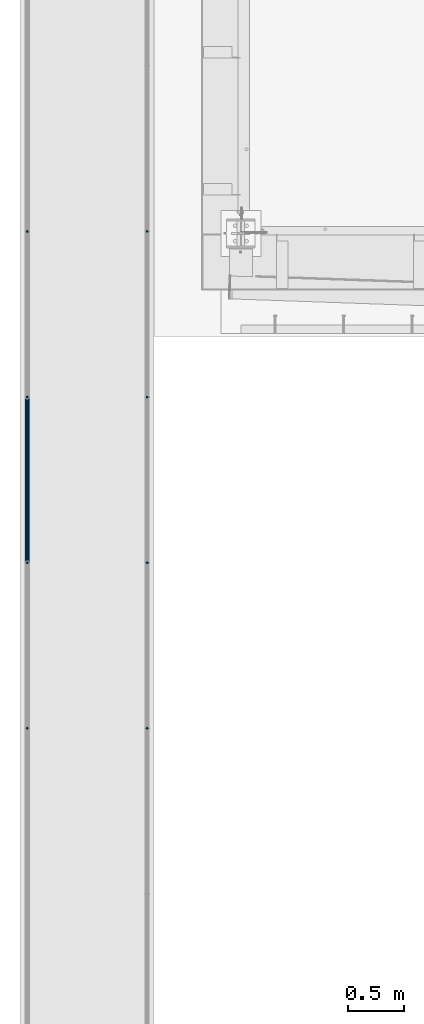
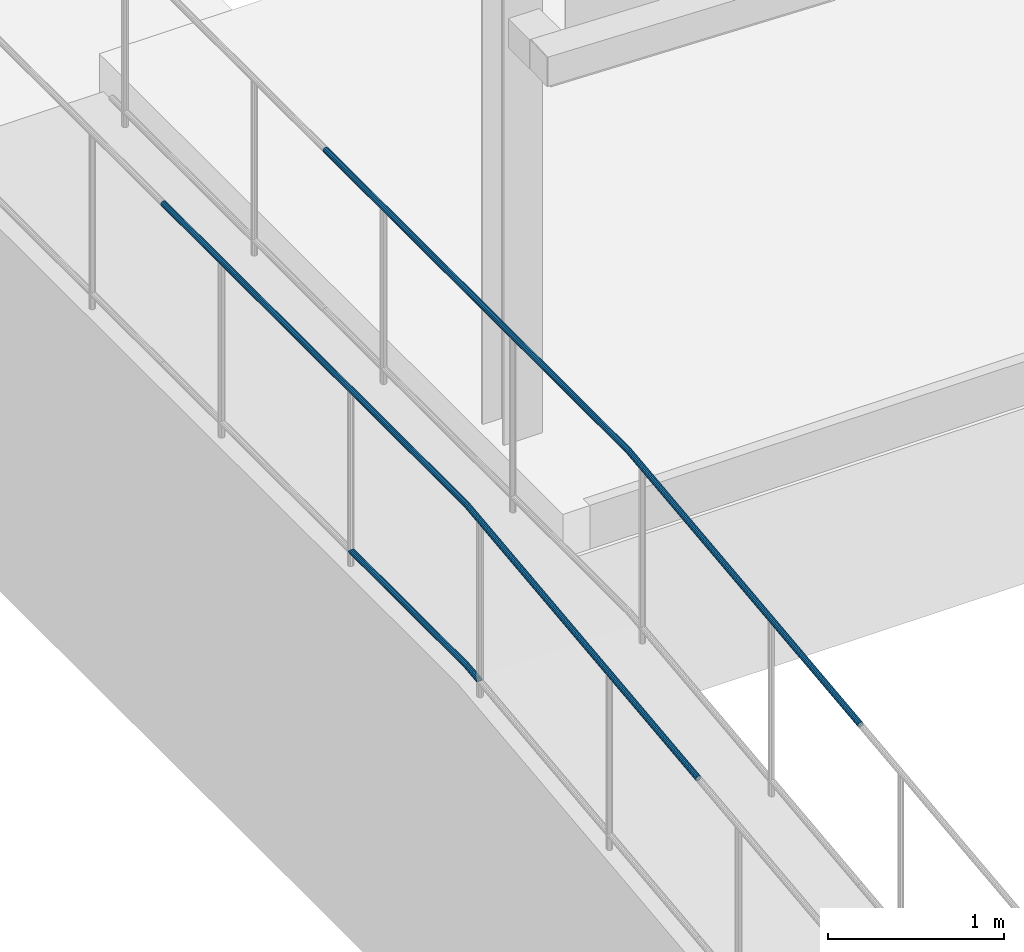
# One storey, part 1045 of 1763: 3 beams, 2 elements without a shape of their own.
"""IFC2X3 building model written with IfcOpenShell, lengths in millimetres."""

import ifcopenshell
import ifcopenshell.guid

model = None  # the IFC model being written
_history = None  # IfcOwnerHistory: only IFC2X3 demands one
_inside = {}  # id of a spatial element -> (the spatial element, [elements in it])
_under = {}  # id of a project, library or spatial element -> (it, [spatial elements below it])
_declared = {}  # id of a project -> (the project, [libraries it declares])
_typed = {}  # id of a type object -> (the type object, [elements of that type])
_made_of = {}  # id of a material, layer set ... -> (it, [elements and type objects made of it])


def new_model(schema):
    """Start an empty IFC model of exactly this schema.

    Asked for "IFC4X3", IfcOpenShell would pick the latest addendum, in which some entities
    have other attributes; the version numbers below select the first issue.
    IFC2X3 requires an IfcOwnerHistory on every rooted entity: one is made here for all.
    """
    global model, _history
    if schema == "IFC4X3":
        model = ifcopenshell.file(schema_version=(4, 3, 0, 0))
    else:
        model = ifcopenshell.file(schema=schema)
    _inside.clear()
    _under.clear()
    _declared.clear()
    _typed.clear()
    _made_of.clear()
    _history = None
    if model.schema == "IFC2X3":
        org = make("IfcOrganization", Name="unknown")
        user = make(
            "IfcPersonAndOrganization",
            ThePerson=make("IfcPerson", FamilyName="unknown"),
            TheOrganization=org,
        )
        app = make(
            "IfcApplication",
            ApplicationDeveloper=org,
            Version="unknown",
            ApplicationFullName="unknown",
            ApplicationIdentifier="unknown",
        )
        _history = make(
            "IfcOwnerHistory",
            OwningUser=user,
            OwningApplication=app,
            ChangeAction="ADDED",
            CreationDate=0,
        )
    return model


def make(cls, **values):
    """One entity of the class cls with the attributes given. An attribute that is None is left unset."""
    return model.create_entity(
        cls, **{name: value for name, value in values.items() if value is not None}
    )


def rooted(cls, **values):
    """An entity with a GlobalId (a new one), such as an element, a storey or a relation."""
    return make(cls, GlobalId=ifcopenshell.guid.new(), OwnerHistory=_history, **values)


def si_unit(unit_type, name, prefix=None):
    """IfcSIUnit, for example si_unit("LENGTHUNIT", "METRE", prefix="MILLI")."""
    return make("IfcSIUnit", UnitType=unit_type, Prefix=prefix, Name=name)


def assignment(units):
    """IfcUnitAssignment: the units of a project."""
    return None if units is None else make("IfcUnitAssignment", Units=units)


def point(xyz):
    """IfcCartesianPoint."""
    return None if xyz is None else make("IfcCartesianPoint", Coordinates=xyz)


def direction(xyz):
    """IfcDirection."""
    return None if xyz is None else make("IfcDirection", DirectionRatios=xyz)


def frame(location, z_axis=None, x_axis=None):
    """IfcAxis2Placement3D, a coordinate frame: its origin and axes. An axis left out is left unset."""
    return make(
        "IfcAxis2Placement3D",
        Location=point(location),
        Axis=direction(z_axis),
        RefDirection=direction(x_axis),
    )


def origin_with_axes():
    """The frame at (0, 0, 0) with the z axis (0, 0, 1) and the x axis (1, 0, 0) written out."""
    return frame((0.0, 0.0, 0.0), z_axis=(0.0, 0.0, 1.0), x_axis=(1.0, 0.0, 0.0))


def place(relative_to, where):
    """IfcLocalPlacement: puts the frame where relative to a parent placement (None: the world)."""
    return make(
        "IfcLocalPlacement", PlacementRelTo=relative_to, RelativePlacement=where
    )


def context(
    kind, dimensions, precision=None, world=None, true_north=None, identifier=None
):
    """IfcGeometricRepresentationContext, for example the 3D "Model" context."""
    return make(
        "IfcGeometricRepresentationContext",
        ContextIdentifier=identifier,
        ContextType=kind,
        CoordinateSpaceDimension=dimensions,
        Precision=precision,
        WorldCoordinateSystem=world,
        TrueNorth=true_north,
    )


def subcontext(parent, identifier, kind, view, scale=None):
    """IfcGeometricRepresentationSubContext, for example "Body" below "Model"."""
    return make(
        "IfcGeometricRepresentationSubContext",
        ContextIdentifier=identifier,
        ContextType=kind,
        ParentContext=parent,
        TargetScale=scale,
        TargetView=view,
    )


def project(units=None, contexts=None):
    """IfcProject with its units and contexts."""
    return rooted(
        "IfcProject",
        Name="project",
        RepresentationContexts=contexts,
        UnitsInContext=assignment(units),
    )


def spatial(cls, under=None, at=None, **own):
    """A site, building, storey or space (cls), placed at a placement, below another one or the project."""
    s = rooted(cls, ObjectPlacement=at, **own)
    if under is not None:
        _under.setdefault(under.id(), (under, []))[1].append(s)
    return s


def faces_of(points, faces, orient=None, outer=None):
    """IfcFace entities. A face is a list of loops; a loop is a list of indices into points, from 0.

    orient and outer hold one flag for each loop. By default every Orientation is true, the
    first loop of a face is its IfcFaceOuterBound and the others are IfcFaceBound.
    """
    made = []
    for i, loops in enumerate(faces):
        bounds = []
        for j, loop in enumerate(loops):
            is_outer = j == 0 if outer is None else outer[i][j]
            bounds.append(
                make(
                    "IfcFaceOuterBound" if is_outer else "IfcFaceBound",
                    Bound=make("IfcPolyLoop", Polygon=[points[k] for k in loop]),
                    Orientation=True if orient is None else orient[i][j],
                )
            )
        made.append(make("IfcFace", Bounds=bounds))
    return made


def faceted_brep(points, faces, orient=None, outer=None, voids=None):
    """IfcFacetedBrep: a solid bounded by flat faces; with voids (closed shells), ...WithVoids."""
    shared = [point(p) for p in points]
    hull = make("IfcClosedShell", CfsFaces=faces_of(shared, faces, orient, outer))
    if voids is None:
        return make("IfcFacetedBrep", Outer=hull)
    return make(
        "IfcFacetedBrepWithVoids",
        Outer=hull,
        Voids=[
            make(cls, CfsFaces=faces_of(shared, fs, o, b)) for cls, fs, o, b in voids
        ],
    )


def shape(context_of_items, identifier, shape_type, items):
    """IfcShapeRepresentation: the items that make up one representation, for example the "Body"."""
    return make(
        "IfcShapeRepresentation",
        ContextOfItems=context_of_items,
        RepresentationIdentifier=identifier,
        RepresentationType=shape_type,
        Items=items,
    )


def material(Name=None, Category=None):
    """IfcMaterial."""
    return make("IfcMaterial", Name=Name, Category=Category)


def made_of(thing, what):
    """Note that an element or type object is made of a material, layer set ...; save() writes the relation."""
    if what is not None:
        _made_of.setdefault(what.id(), (what, []))[1].append(thing)
    return thing


def type_object(cls, material=None, **own):
    """A type object (cls), such as IfcWallType, which elements share."""
    return made_of(rooted(cls, **own), material)


def element(
    cls,
    number,
    at=None,
    inside=None,
    cuts=None,
    type_object=None,
    material=None,
    context=None,
    identifier="Body",
    shape_type=None,
    held_by="IfcProductDefinitionShape",
    body=None,
    shapes=None,
    **own,
):
    """One element of the class cls, such as IfcWall. Its Tag is "e" and its number.

    at: its placement. inside: the storey or other place that contains it. cuts: it is an
    opening in that element (IfcRelVoidsElement). A single representation is given by context,
    identifier, shape_type and body (its items); several are given by shapes. held_by: the class
    of the entity that holds the representations. save() writes the other relations.
    """
    e = rooted(cls, Tag="e%d" % number, ObjectPlacement=at, **own)
    if body is not None:
        shapes = [shape(context, identifier, shape_type, body)]
    if shapes is not None:
        e.Representation = make(held_by, Representations=shapes)
    if inside is not None:
        _inside.setdefault(inside.id(), (inside, []))[1].append(e)
    if cuts is not None:
        rooted(
            "IfcRelVoidsElement", RelatingBuildingElement=cuts, RelatedOpeningElement=e
        )
    if type_object is not None:
        _typed.setdefault(type_object.id(), (type_object, []))[1].append(e)
    return made_of(e, material)


def aggregate(whole, parts):
    """IfcRelAggregates: a whole, such as a stair, and the parts it consists of."""
    return rooted("IfcRelAggregates", RelatingObject=whole, RelatedObjects=parts)


def save(model, path):
    """Write the relations noted so far, then the file.

    IfcRelAggregates (storeys below a building ...), IfcRelContainedInSpatialStructure (elements
    in a storey), IfcRelDefinesByType, IfcRelAssociatesMaterial and IfcRelDeclares: one each for
    every whole, place, type object, material and project.
    """
    for whole, parts in _under.values():
        aggregate(whole, parts)
    for where, things in _inside.values():
        rooted(
            "IfcRelContainedInSpatialStructure",
            RelatedElements=things,
            RelatingStructure=where,
        )
    for kind, things in _typed.values():
        rooted("IfcRelDefinesByType", RelatedObjects=things, RelatingType=kind)
    for what, things in _made_of.values():
        rooted("IfcRelAssociatesMaterial", RelatedObjects=things, RelatingMaterial=what)
    for by, libraries in _declared.values():
        rooted("IfcRelDeclares", RelatingContext=by, RelatedDefinitions=libraries)
    model.write(path)


model = new_model("IFC2X3")

# Units and contexts
model_context = context("Model", 3, precision=1e-05, world=origin_with_axes())
body_context = subcontext(model_context, "Body", "Model", "MODEL_VIEW")
ifc_project = project(units=[si_unit("LENGTHUNIT", "METRE", prefix="MILLI"), si_unit("AREAUNIT", "SQUARE_METRE"), si_unit("VOLUMEUNIT", "CUBIC_METRE"), si_unit("MASSUNIT", "GRAM", prefix="KILO"), si_unit("TIMEUNIT", "SECOND"), si_unit("PLANEANGLEUNIT", "RADIAN"), si_unit("SOLIDANGLEUNIT", "STERADIAN"), si_unit("THERMODYNAMICTEMPERATUREUNIT", "DEGREE_CELSIUS"), si_unit("LUMINOUSINTENSITYUNIT", "LUMEN")], contexts=[model_context])

# Site, building, storey
site_placement = place(None, origin_with_axes())
site = spatial("IfcSite", under=ifc_project, at=site_placement, CompositionType="ELEMENT")
building_placement = place(site_placement, origin_with_axes())
building = spatial("IfcBuilding", under=site, at=building_placement, Name="Undefined", CompositionType="ELEMENT")
storey_placement = place(building_placement, origin_with_axes())
storey = spatial("IfcBuildingStorey", under=building, at=storey_placement, Name="Undefined", CompositionType="ELEMENT", Elevation=0.0)

# Assembly, beams
assembly_1_placement = place(storey_placement, origin_with_axes())
assembly_1 = element("IfcElementAssembly", 1, at=assembly_1_placement, inside=storey, Name="GUARDRAIL", AssemblyPlace="NOTDEFINED", PredefinedType="RIGID_FRAME")
ifc_material = material(Name="STEEL/A513")
beam_type = type_object("IfcBeamType", PredefinedType="NOTDEFINED")
beam_1_placement = place(assembly_1_placement, frame((-97200.6527017878, 7842.04321744867, 6031.68571661139), z_axis=(0.0, 0.000110293999990972, 0.999999993917617), x_axis=(0.0, -0.999999993917617, 0.000110293999990572)))
beam_1 = element("IfcBeam", 2, at=beam_1_placement, type_object=beam_type, material=ifc_material, Name="GUARDRAIL", context=body_context, shape_type="Brep", body=[
    faceted_brep([(0.0, 19.0500000000029, 0.0), (9.52389918579229, 16.4977839420899, -9.52500000270356), (9.5259929141539, 16.4977839420899, 9.52499999728934), (9.5259929141539, -16.4977839420899, 9.52499999728934), (9.52389918579229, -16.4977839420899, -9.52500000270356), (0.0, -19.0500000000029, 0.0), (16.4995432561273, -9.52499999999418, 16.4977839373987), (16.4989903061414, -9.52499999999418, 11.4667123752624), (12.7153621018151, -13.3082123799541, 7.68349999638394), (10.6557299988963, -15.3669999999984, -3.02861735690385e-09), (12.7136731609353, -13.3082123799541, -7.68350000361079), (16.4964697622117, -9.52499999999418, -11.4667123846402), (16.4959168122259, -9.52499999999418, -16.4977839467765), (19.048257166618, 0.0, -15.367000005409), (19.0478523791344, 0.0, -19.0500000054071), (16.9896958093113, -7.68349999999919, -13.3082123847798), (16.9896958093104, 7.68349999999919, -13.3082123847798), (16.4964697622117, 9.52499999999418, -11.4667123846402), (16.4959168122259, 9.52499999999418, -16.4977839467765), (12.7136731609326, 13.3082123799541, -7.68350000361079), (10.6557299988926, 15.3669999999984, -3.02861735690385e-09), (12.7153621018115, 13.3082123799541, 7.68349999638394), (16.4989903061414, 9.52499999999418, 11.4667123752624), (16.4995432561273, 9.52499999999418, 16.4977839373987), (16.9926211407237, 7.68349999999919, 13.3082123751219), (19.0516350483749, 0.0, 15.3669999945805), (19.0520398358585, 0.0, 19.0499999945787), (16.9926211407255, -7.68349999999919, 13.3082123751219), (1319.9343412278, 7.68349999999919, 13.3082120047329), (1319.9343412262, 13.3082123799541, 7.68349962477896), (1321.9654584977, 13.3082123799541, 7.68349962420052), (1322.2876046557, 7.68349999999919, 13.3082120040635), (1323.98329424224, 13.3082123799541, 7.45160249476521), (1324.62548003482, 7.68349999999919, 13.0395347388976), (1456.21371452531, 7.68349999999919, -2.08307072021216), (1460.48971040597, 13.3082123799541, -8.23621854998237), (1456.70694273159, 9.52499999999418, -3.99337519920118), (1323.10605213563, 15.3669999999984, -0.181654905345567), (1462.54766257699, 15.3669999999984, -16.2067993071423), (1321.52539866214, 15.3669999999984, -3.75671334040817e-07), (1319.93434122402, 15.3669999999984, -3.75219315174036e-07), (1319.93434122183, 13.3082123799541, -7.68350037521668), (1321.08533882658, 13.3082123799541, -7.68350037554319), (1322.22881002902, 13.3082123799541, -7.81491230545726), (1460.48808908531, 13.3082123799541, -23.7041788217603), (1321.58662423644, 7.68349999999919, -13.4028445495896), (1456.21090631555, 7.68349999999919, -28.874363800388), (1456.70452310281, 9.52499999999418, -27.0774711894464), (1320.76319266858, 7.68349999999919, -13.3082127554053), (1319.93434122024, 7.68349999999919, -13.3082127551697), (1319.93434121965, 0.0, -15.3670003752131), (1320.64527899102, 0.0, -15.367000375415), (1321.35156792241, 0.0, -15.448169705568), (1454.15192626841, 0.0, -30.7100769108065), (1319.9343412186, 0.0, -19.0500003752131), (1319.93434121933, -9.52499999999418, -16.4977843173065), (1319.93434122131, -16.4977839420899, -9.52500037521531), (1319.93434122402, -19.0500000000029, -3.75219315174036e-07), (1320.97986994037, -16.4977839420899, -9.52500037551363), (1321.52539866214, -19.0500000000029, -3.75670424546115e-07), (1319.93434122672, -16.4977839420899, 9.52499962477941), (1319.93434122871, -9.52499999999418, 16.4977835668697), (1319.93434122943, 0.0, 19.0499996247754), (1319.93434122131, 16.4977839420899, -9.52500037521531), (1319.93434121933, 9.52499999999418, -16.4977843173065), (1319.93434122402, 19.0500000000029, -3.75219315174036e-07), (1319.93434122672, 16.4977839420899, 9.52499962477941), (1319.93434122871, 9.52499999999418, 16.4977835668697), (1320.58051519905, 9.52499999999418, -16.4977843174911), (1320.4343412186, 0.0, -19.0500003753541), (1320.58051519905, -9.52499999999418, -16.4977843174911), (1321.22246383085, -9.52499999999418, -16.5715594230041), (1322.01856192082, -16.4977839420899, -9.6443706906075), (1323.10605213563, -19.0500000000029, -0.181654905345567), (1322.07092738391, -16.4977839420899, 9.52499962417096), (1324.19354235044, -16.4977839420899, 9.28106087991546), (1322.47028212523, -9.52499999999418, 16.4977835661493), (1322.61645610568, 0.0, 19.0499996240133), (1322.47028212523, 9.52499999999418, 16.4977835661493), (1322.07092738391, 16.4977839420899, 9.52499962417096), (1321.52539866214, 19.0500000000029, -3.75670424546115e-07), (1320.97986994037, 16.4977839420899, -9.52500037551363), (1322.01856192082, 16.4977839420899, -9.6443706906075), (1321.22246383085, 9.52499999999418, -16.5715594230041), (1320.93107170602, 0.0, -19.1070864758694), (1454.15153768743, 0.0, -34.4172740007371), (1456.70399229131, -9.52499999999418, -32.1415965911274), (1463.67742795313, -16.4977839420899, -25.9243302864352), (1473.20331821774, -19.0500000000029, -17.4313969549685), (1463.67943785478, -16.4977839420899, -6.74917292472765), (1324.98964044041, -9.52499999999418, 16.2082496123112), (1456.70747354309, -9.52499999999418, 1.07075020247976), (1325.28103256525, 0.0, 18.7437766651783), (1324.98964044041, 9.52499999999418, 16.2082496123112), (1324.19354235044, 16.4977839420899, 9.28106087991546), (1323.10605213563, 19.0500000000029, -0.181654905345567), (1473.20340864678, 19.0500000000029, -17.4313969644472), (1463.67742795313, 16.4977839420899, -25.9243302864352), (1456.70399229131, 9.52499999999418, -32.1415965911274), (1456.70452310281, -9.52499999999418, -27.0774711894464), (1456.21090631555, -7.68349999999919, -28.8743638003871), (1321.58662423644, -7.68349999999919, -13.4028445495896), (1320.76319266858, -7.68349999999919, -13.3082127554053), (1319.93434122024, -7.68349999999919, -13.3082127551697), (1319.93434122183, -13.3082123799541, -7.68350037521668), (1321.08533882658, -13.3082123799541, -7.68350037554319), (1322.22881002902, -13.3082123799541, -7.81491230545726), (1460.4880890853, -13.3082123799541, -23.7041788217603), (1323.10605213563, -15.3669999999984, -0.181654905345567), (1462.54766257699, -15.3669999999984, -16.2067993071414), (1321.52539866214, -15.3669999999984, -3.75670424546115e-07), (1319.93434122402, -15.3669999999984, -3.75219315174036e-07), (1319.9343412262, -13.3082123799541, 7.68349962477896), (1321.9654584977, -13.3082123799541, 7.68349962420052), (1323.98329424224, -13.3082123799541, 7.45160249476521), (1460.48971040597, -13.3082123799541, -8.23621854998237), (1456.70694273159, -9.52499999999418, -3.99337519920118), (1324.62548003482, -7.68349999999919, 13.0395347388976), (1456.21371452531, -7.68349999999919, -2.08307072021216), (1322.2876046557, -7.68349999999919, 13.3082120040635), (1319.9343412278, -7.68349999999919, 13.3082120047329), (1319.93434122838, 0.0, 15.3669996247763), (1322.40551833326, 0.0, 15.3669996240733), (1324.86053634886, 0.0, 15.084859894876), (1454.15516890974, 0.0, 0.225843632748365), (1454.15555749073, 0.0, 3.93304072267892), (1456.70747354309, 9.52499999999418, 1.07075020247976), (1463.67943785478, 16.4977839420899, -6.74917292472765)], [[[0, 1, 2]], [[3, 4, 5]], [[6, 7, 8, 9, 10, 11, 12, 4, 3]], [[13, 14, 12, 11, 15]], [[16, 17, 18, 14, 13]], [[2, 1, 18, 17, 19, 20, 21, 22, 23]], [[23, 22, 24, 25, 26]], [[26, 25, 27, 7, 6]], [[28, 29, 30, 31]], [[31, 30, 32, 33]], [[34, 33, 32, 35, 36]], [[32, 37, 38, 35]], [[30, 39, 37, 32]], [[29, 40, 39, 30]], [[40, 41, 42, 39]], [[39, 42, 43, 37]], [[37, 43, 44, 38]], [[43, 45, 46, 47, 44]], [[42, 48, 45, 43]], [[41, 49, 48, 42]], [[49, 50, 51, 48]], [[48, 51, 52, 45]], [[45, 52, 53, 46]], [[54, 55, 12, 14]], [[55, 56, 4, 12]], [[57, 56, 58, 59]], [[56, 57, 5, 4]], [[57, 60, 3, 5]], [[60, 61, 6, 3]], [[61, 62, 26, 6]], [[63, 64, 18, 1]], [[65, 63, 1, 0]], [[66, 65, 0, 2]], [[67, 66, 2, 23]], [[62, 67, 23, 26]], [[64, 54, 14, 18]], [[54, 64, 68, 69]], [[55, 54, 69, 70]], [[56, 55, 70, 58]], [[58, 70, 71, 72]], [[59, 58, 72, 73]], [[74, 59, 73, 75]], [[60, 57, 59, 74]], [[61, 60, 74, 76]], [[62, 61, 76, 77]], [[67, 62, 77, 78]], [[66, 67, 78, 79]], [[65, 66, 79, 80]], [[63, 65, 80, 81]], [[64, 63, 81, 68]], [[68, 81, 82, 83]], [[69, 68, 83, 84]], [[70, 69, 84, 71]], [[71, 84, 85, 86]], [[72, 71, 86, 87]], [[73, 72, 87, 88]], [[88, 87, 89]], [[75, 73, 88, 89]], [[90, 75, 89, 91]], [[76, 74, 75, 90]], [[77, 76, 90, 92]], [[78, 77, 92, 93]], [[79, 78, 93, 94]], [[80, 79, 94, 95]], [[81, 80, 95, 82]], [[82, 95, 96, 97]], [[83, 82, 97, 98]], [[84, 83, 98, 85]], [[46, 53, 85, 98, 47]], [[99, 86, 85, 53, 100]], [[52, 101, 100, 53]], [[51, 102, 101, 52]], [[50, 103, 102, 51]], [[103, 104, 105, 102]], [[102, 105, 106, 101]], [[100, 101, 106, 107, 99]], [[106, 108, 109, 107]], [[105, 110, 108, 106]], [[104, 111, 110, 105]], [[111, 112, 113, 110]], [[110, 113, 114, 108]], [[108, 114, 115, 109]], [[89, 87, 86, 99, 107, 109, 115, 116, 91]], [[114, 117, 118, 116, 115]], [[113, 119, 117, 114]], [[112, 120, 119, 113]], [[120, 121, 122, 119]], [[119, 122, 123, 117]], [[117, 123, 124, 118]], [[91, 116, 118, 124, 125]], [[92, 90, 91, 125]], [[93, 92, 125, 126]], [[94, 93, 126, 127]], [[95, 94, 127, 96]], [[96, 127, 97]], [[126, 36, 35, 38, 44, 47, 98, 97, 127]], [[125, 124, 34, 36, 126]], [[123, 33, 34, 124]], [[122, 31, 33, 123]], [[121, 28, 31, 122]], [[28, 121, 25, 24]], [[21, 29, 28, 24, 22]], [[40, 29, 21, 20]], [[41, 40, 20, 19]], [[49, 41, 19, 17, 16]], [[50, 49, 16, 13]], [[103, 50, 13, 15]], [[10, 104, 103, 15, 11]], [[111, 104, 10, 9]], [[112, 111, 9, 8]], [[120, 112, 8, 7, 27]], [[121, 120, 27, 25]]]),
])
beam_2_placement = place(assembly_1_placement, frame((-97200.6527017878, 9975.70609643673, 7149.43146284773), z_axis=(1.0, 0.0, 0.0), x_axis=(0.0, -1.0, 0.0)))
beam_2 = element("IfcBeam", 3, at=beam_2_placement, type_object=beam_type, material=ifc_material, Name="GUARDRAIL", context=body_context, shape_type="Brep", body=[
    faceted_brep([(0.0, -19.0500000000029, 0.0), (0.0, -16.4977839420899, -9.52500000000146), (3453.59822932825, -16.4977839420935, -9.52499999999418), (3453.59822932825, -19.0500000000002, 0.0), (0.0, -9.52499999999418, -16.4977839420935), (3453.59822932825, -9.52499999999964, -16.4977839420899), (1.45519152283669e-11, 1.81898940354586e-12, -19.0499999999993), (3453.59822932825, 0.0, -19.0500000000029), (0.0, 9.52499999999418, -16.4977839420935), (3453.59822932825, 9.52499999999964, -16.4977839420899), (0.0, 16.4977839420899, -9.52500000000146), (3453.59822932825, 16.4977839420935, -9.52499999999418), (0.0, 19.0500000000029, 0.0), (3453.59822932825, 19.0500000000002, 0.0), (0.0, 16.4977839420899, 9.52500000000146), (3453.59822932825, 16.4977839420935, 9.52499999999418), (0.0, 9.52499999999418, 16.4977839420935), (3453.59822932825, 9.52499999999964, 16.4977839420899), (1.45519152283669e-11, 1.81898940354586e-12, 19.0499999999993), (3453.59822932825, 0.0, 19.0500000000029), (0.0, -9.52499999999418, 16.4977839420935), (3453.59822932825, -9.52499999999964, 16.4977839420899), (0.0, -16.4977839420899, 9.52500000000146), (3453.59822932825, -16.4977839420935, 9.52499999999418), (4.71409293822944e-08, -15.3669999999984, 0.0), (-1.81898940354586e-12, -13.3082123799541, 7.68349999999919), (3453.59822932825, -13.3082123799559, 7.68349999999919), (3453.59822932825, -15.3670000000002, 0.0), (-3.63797880709171e-12, -7.68349999999919, 13.3082123799531), (3453.59822932825, -7.68350000000009, 13.3082123799541), (-1.81898940354586e-12, 0.0, 15.3669999999966), (3453.59822932825, 0.0, 15.3669999999984), (-3.63797880709171e-12, 7.68349999999919, 13.3082123799531), (3453.59822932825, 7.68350000000009, 13.3082123799541), (-1.81898940354586e-12, 13.3082123799541, 7.68349999999919), (3453.59822932825, 13.3082123799559, 7.68349999999919), (4.71409293822944e-08, 15.3669999999984, 0.0), (3453.59822932825, 15.3670000000002, 0.0), (3.63797880709171e-12, 13.3082123799541, -7.68349999999737), (3453.59822932825, 13.3082123799559, -7.68349999999919), (3.63797880709171e-12, 7.68349999999919, -13.3082123799522), (3453.59822932825, 7.68350000000009, -13.3082123799541), (3.63797880709171e-12, 0.0, -15.3669999999956), (3453.59822932825, 0.0, -15.3669999999984), (3.63797880709171e-12, -7.68349999999919, -13.3082123799522), (3453.59822932825, -7.68350000000009, -13.3082123799541), (3.63797880709171e-12, -13.3082123799541, -7.68349999999737), (3453.59822932825, -13.3082123799559, -7.68349999999919), (3456.13220279116, -16.4977839420935, -9.52499999999418), (3456.2782355155, -19.0500000000002, 0.0), (3455.73323396869, -9.52499999999964, -16.4977839420899), (3455.18823242188, 0.0, -19.0500000000029), (3454.64323087506, 9.52499999999964, -16.4977839420899), (3454.24426205259, 16.4977839420935, -9.52499999999418), (3454.09822932825, 19.0500000000002, 0.0), (3454.24426205259, 16.4977839420935, 9.52499999999418), (3454.64323087506, 9.52499999999964, 16.4977839420899), (3455.18823242188, 0.0, 19.0500000000029), (3455.73323396869, -9.52499999999964, 16.4977839420899), (3456.13220279116, -16.4977839420935, 9.52499999999418), (3455.9497018531, -13.3082123799559, 7.68349999999919), (3456.06750158407, -15.3670000000002, 0.0), (3455.62786700297, -7.68350000000009, 13.3082123799541), (3455.18823242188, 0.0, 15.3669999999984), (3454.74859784078, 7.68350000000009, 13.3082123799541), (3454.42676299065, 13.3082123799559, 7.68349999999919), (3454.30896325968, 15.3670000000002, 0.0), (3454.42676299065, 13.3082123799559, -7.68349999999919), (3454.74859784078, 7.68350000000009, -13.3082123799541), (3455.18823242188, 0.0, -15.3669999999984), (3455.62786700297, -7.68350000000009, -13.3082123799541), (3455.9497018531, -13.3082123799559, -7.68349999999919), (3458.6496384423, -16.2087523640621, -9.52499999999418), (3458.94075081798, -18.7443115510987, 0.0), (3457.85430464124, -9.28147583948248, -16.4977839420899), (3456.76785846449, 0.181359872134635, -19.0500000000029), (3455.68141228775, 9.64419558375084, -16.4977839420899), (3454.88607848669, 16.5714721083314, -9.52499999999418), (3454.59496611101, 19.1070312953671, 0.0), (3454.88607848669, 16.5714721083314, 9.52499999999418), (3455.68141228775, 9.64419558375084, 16.4977839420899), (3456.76785846449, 0.181359872134635, 19.0500000000029), (3457.85430464124, -9.28147583948248, 16.4977839420899), (3458.6496384423, -16.2087523640621, 9.52499999999418), (3458.28582764659, -13.0399973317308, 7.68349999999919), (3458.52065829631, -15.0853484092731, 0.0), (3457.6442583804, -7.45199426856925, 13.3082123799541), (3456.76785846449, 0.181359872134635, 15.3669999999984), (3455.89145854859, 7.81471401283852, 13.3082123799541), (3455.2498892824, 13.402717076, 7.68349999999919), (3455.01505863268, 15.4480681535424, 0.0), (3455.2498892824, 13.402717076, -7.68349999999919), (3455.89145854859, 7.81471401283852, -13.3082123799541), (3456.76785846449, 0.181359872134635, -15.3669999999984), (3457.6442583804, -7.45199426856925, -13.3082123799541), (3458.28582764659, -13.0399973317308, -7.68349999999919), (6097.8817799778, 286.806512519663, -9.52499999999418), (6098.17289235348, 284.270953332627, 0.0), (6097.08644617674, 293.733789044243, -16.4977839420899), (6096.0, 303.196624755859, -19.0500000000029), (6094.91355382326, 312.659460467476, -16.4977839420899), (6094.1182200222, 319.586736992056, -9.52499999999418), (6093.82710764652, 322.122296179092, 0.0), (6094.1182200222, 319.586736992056, 9.52499999999418), (6094.91355382326, 312.659460467476, 16.4977839420899), (6096.0, 303.196624755859, 19.0500000000029), (6097.08644617674, 293.733789044243, 16.4977839420899), (6097.8817799778, 286.806512519663, 9.52499999999418), (6097.51796918209, 289.975267551994, 7.68349999999919), (6097.75279983181, 287.929916474452, 0.0), (6096.8763999159, 295.563270615155, 13.3082123799541), (6096.0, 303.196624755859, 15.3669999999984), (6095.1236000841, 310.829978896563, 13.3082123799541), (6094.48203081791, 316.417981959725, 7.68349999999919), (6094.24720016819, 318.463333037267, 0.0), (6094.48203081791, 316.417981959725, -7.68349999999919), (6095.1236000841, 310.829978896563, -13.3082123799541), (6096.0, 303.196624755859, -15.3669999999984), (6096.8763999159, 295.563270615155, -13.3082123799541), (6097.51796918209, 289.975267551994, -7.68349999999919)], [[[0, 1, 2, 3]], [[1, 4, 5, 2]], [[4, 6, 7, 5]], [[6, 8, 9, 7]], [[8, 10, 11, 9]], [[10, 12, 13, 11]], [[12, 14, 15, 13]], [[14, 16, 17, 15]], [[16, 18, 19, 17]], [[18, 20, 21, 19]], [[20, 22, 23, 21]], [[22, 0, 3, 23]], [[24, 25, 26, 27]], [[25, 28, 29, 26]], [[28, 30, 31, 29]], [[30, 32, 33, 31]], [[32, 34, 35, 33]], [[34, 36, 37, 35]], [[36, 38, 39, 37]], [[38, 40, 41, 39]], [[40, 42, 43, 41]], [[42, 44, 45, 43]], [[44, 46, 47, 45]], [[46, 24, 27, 47]], [[22, 20, 18, 16, 14, 12, 10, 8, 6, 4, 1, 0], [46, 44, 42, 40, 38, 36, 34, 32, 30, 28, 25, 24]], [[3, 2, 48, 49]], [[2, 5, 50, 48]], [[5, 7, 51, 50]], [[7, 9, 52, 51]], [[9, 11, 53, 52]], [[11, 13, 54, 53]], [[13, 15, 55, 54]], [[15, 17, 56, 55]], [[17, 19, 57, 56]], [[19, 21, 58, 57]], [[21, 23, 59, 58]], [[23, 3, 49, 59]], [[27, 26, 60, 61]], [[26, 29, 62, 60]], [[29, 31, 63, 62]], [[31, 33, 64, 63]], [[33, 35, 65, 64]], [[35, 37, 66, 65]], [[37, 39, 67, 66]], [[39, 41, 68, 67]], [[41, 43, 69, 68]], [[43, 45, 70, 69]], [[45, 47, 71, 70]], [[47, 27, 61, 71]], [[49, 48, 72, 73]], [[48, 50, 74, 72]], [[50, 51, 75, 74]], [[51, 52, 76, 75]], [[52, 53, 77, 76]], [[53, 54, 78, 77]], [[54, 55, 79, 78]], [[55, 56, 80, 79]], [[56, 57, 81, 80]], [[57, 58, 82, 81]], [[58, 59, 83, 82]], [[59, 49, 73, 83]], [[61, 60, 84, 85]], [[60, 62, 86, 84]], [[62, 63, 87, 86]], [[63, 64, 88, 87]], [[64, 65, 89, 88]], [[65, 66, 90, 89]], [[66, 67, 91, 90]], [[67, 68, 92, 91]], [[68, 69, 93, 92]], [[69, 70, 94, 93]], [[70, 71, 95, 94]], [[71, 61, 85, 95]], [[73, 72, 96, 97]], [[72, 74, 98, 96]], [[74, 75, 99, 98]], [[75, 76, 100, 99]], [[76, 77, 101, 100]], [[77, 78, 102, 101]], [[78, 79, 103, 102]], [[79, 80, 104, 103]], [[80, 81, 105, 104]], [[81, 82, 106, 105]], [[82, 83, 107, 106]], [[83, 73, 97, 107]], [[85, 84, 108, 109]], [[84, 86, 110, 108]], [[86, 87, 111, 110]], [[87, 88, 112, 111]], [[88, 89, 113, 112]], [[89, 90, 114, 113]], [[90, 91, 115, 114]], [[91, 92, 116, 115]], [[92, 93, 117, 116]], [[93, 94, 118, 117]], [[94, 95, 119, 118]], [[95, 85, 109, 119]], [[98, 99, 100, 101, 102, 103, 104, 105, 106, 107, 97, 96], [110, 111, 112, 113, 114, 115, 116, 117, 118, 119, 109, 108]]]),
])
aggregate(assembly_1, [beam_1, beam_2])

# Assembly, beam
assembly_2_placement = place(storey_placement, origin_with_axes())
assembly_2 = element("IfcElementAssembly", 4, at=assembly_2_placement, inside=storey, Name="GUARDRAIL", AssemblyPlace="NOTDEFINED", PredefinedType="RIGID_FRAME")
beam_3_placement = place(assembly_2_placement, frame((-96133.8527017878, 9975.70609643673, 7149.43146284773), z_axis=(1.0, 0.0, 0.0), x_axis=(0.0, -1.0, 0.0)))
beam_3 = element("IfcBeam", 5, at=beam_3_placement, type_object=beam_type, material=ifc_material, Name="GUARDRAIL", context=body_context, shape_type="Brep", body=[
    faceted_brep([(0.0, -19.0500000000029, 0.0), (0.0, -16.4977839420899, -9.52500000000146), (3453.59822932825, -16.4977839420935, -9.52499999999418), (3453.59822932825, -19.0500000000002, 0.0), (0.0, -9.52499999999418, -16.4977839420935), (3453.59822932825, -9.52499999999964, -16.4977839420899), (1.45519152283669e-11, 1.81898940354586e-12, -19.0499999999993), (3453.59822932825, 0.0, -19.0500000000029), (0.0, 9.52499999999418, -16.4977839420935), (3453.59822932825, 9.52499999999964, -16.4977839420899), (0.0, 16.4977839420899, -9.52500000000146), (3453.59822932825, 16.4977839420935, -9.52499999999418), (0.0, 19.0500000000029, 0.0), (3453.59822932825, 19.0500000000002, 0.0), (0.0, 16.4977839420899, 9.52500000000146), (3453.59822932825, 16.4977839420935, 9.52499999999418), (0.0, 9.52499999999418, 16.4977839420935), (3453.59822932825, 9.52499999999964, 16.4977839420899), (1.45519152283669e-11, 1.81898940354586e-12, 19.0499999999993), (3453.59822932825, 0.0, 19.0500000000029), (0.0, -9.52499999999418, 16.4977839420935), (3453.59822932825, -9.52499999999964, 16.4977839420899), (0.0, -16.4977839420899, 9.52500000000146), (3453.59822932825, -16.4977839420935, 9.52499999999418), (4.71409293822944e-08, -15.3669999999984, 0.0), (-1.81898940354586e-12, -13.3082123799541, 7.68349999999919), (3453.59822932825, -13.3082123799559, 7.68349999999919), (3453.59822932825, -15.3670000000002, 0.0), (-3.63797880709171e-12, -7.68349999999919, 13.3082123799531), (3453.59822932825, -7.68350000000009, 13.3082123799541), (-1.81898940354586e-12, 0.0, 15.3669999999966), (3453.59822932825, 0.0, 15.3669999999984), (-3.63797880709171e-12, 7.68349999999919, 13.3082123799531), (3453.59822932825, 7.68350000000009, 13.3082123799541), (-1.81898940354586e-12, 13.3082123799541, 7.68349999999919), (3453.59822932825, 13.3082123799559, 7.68349999999919), (4.71409293822944e-08, 15.3669999999984, 0.0), (3453.59822932825, 15.3670000000002, 0.0), (3.63797880709171e-12, 13.3082123799541, -7.68349999999737), (3453.59822932825, 13.3082123799559, -7.68349999999919), (3.63797880709171e-12, 7.68349999999919, -13.3082123799522), (3453.59822932825, 7.68350000000009, -13.3082123799541), (3.63797880709171e-12, 0.0, -15.3669999999956), (3453.59822932825, 0.0, -15.3669999999984), (3.63797880709171e-12, -7.68349999999919, -13.3082123799522), (3453.59822932825, -7.68350000000009, -13.3082123799541), (3.63797880709171e-12, -13.3082123799541, -7.68349999999737), (3453.59822932825, -13.3082123799559, -7.68349999999919), (3456.13220279116, -16.4977839420935, -9.52499999999418), (3456.2782355155, -19.0500000000002, 0.0), (3455.73323396869, -9.52499999999964, -16.4977839420899), (3455.18823242188, 0.0, -19.0500000000029), (3454.64323087506, 9.52499999999964, -16.4977839420899), (3454.24426205259, 16.4977839420935, -9.52499999999418), (3454.09822932825, 19.0500000000002, 0.0), (3454.24426205259, 16.4977839420935, 9.52499999999418), (3454.64323087506, 9.52499999999964, 16.4977839420899), (3455.18823242188, 0.0, 19.0500000000029), (3455.73323396869, -9.52499999999964, 16.4977839420899), (3456.13220279116, -16.4977839420935, 9.52499999999418), (3455.9497018531, -13.3082123799559, 7.68349999999919), (3456.06750158407, -15.3670000000002, 0.0), (3455.62786700297, -7.68350000000009, 13.3082123799541), (3455.18823242188, 0.0, 15.3669999999984), (3454.74859784078, 7.68350000000009, 13.3082123799541), (3454.42676299065, 13.3082123799559, 7.68349999999919), (3454.30896325968, 15.3670000000002, 0.0), (3454.42676299065, 13.3082123799559, -7.68349999999919), (3454.74859784078, 7.68350000000009, -13.3082123799541), (3455.18823242188, 0.0, -15.3669999999984), (3455.62786700297, -7.68350000000009, -13.3082123799541), (3455.9497018531, -13.3082123799559, -7.68349999999919), (3458.6496384423, -16.2087523640621, -9.52499999999418), (3458.94075081798, -18.7443115510987, 0.0), (3457.85430464124, -9.28147583948248, -16.4977839420899), (3456.76785846449, 0.181359872134635, -19.0500000000029), (3455.68141228775, 9.64419558375084, -16.4977839420899), (3454.88607848669, 16.5714721083314, -9.52499999999418), (3454.59496611101, 19.1070312953671, 0.0), (3454.88607848669, 16.5714721083314, 9.52499999999418), (3455.68141228775, 9.64419558375084, 16.4977839420899), (3456.76785846449, 0.181359872134635, 19.0500000000029), (3457.85430464124, -9.28147583948248, 16.4977839420899), (3458.6496384423, -16.2087523640621, 9.52499999999418), (3458.28582764659, -13.0399973317308, 7.68349999999919), (3458.52065829631, -15.0853484092731, 0.0), (3457.6442583804, -7.45199426856925, 13.3082123799541), (3456.76785846449, 0.181359872134635, 15.3669999999984), (3455.89145854859, 7.81471401283852, 13.3082123799541), (3455.2498892824, 13.402717076, 7.68349999999919), (3455.01505863268, 15.4480681535424, 0.0), (3455.2498892824, 13.402717076, -7.68349999999919), (3455.89145854859, 7.81471401283852, -13.3082123799541), (3456.76785846449, 0.181359872134635, -15.3669999999984), (3457.6442583804, -7.45199426856925, -13.3082123799541), (3458.28582764659, -13.0399973317308, -7.68349999999919), (6097.8817799778, 286.806512519663, -9.52499999999418), (6098.17289235348, 284.270953332627, 0.0), (6097.08644617674, 293.733789044243, -16.4977839420899), (6096.0, 303.196624755859, -19.0500000000029), (6094.91355382326, 312.659460467476, -16.4977839420899), (6094.1182200222, 319.586736992056, -9.52499999999418), (6093.82710764652, 322.122296179092, 0.0), (6094.1182200222, 319.586736992056, 9.52499999999418), (6094.91355382326, 312.659460467476, 16.4977839420899), (6096.0, 303.196624755859, 19.0500000000029), (6097.08644617674, 293.733789044243, 16.4977839420899), (6097.8817799778, 286.806512519663, 9.52499999999418), (6097.51796918209, 289.975267551994, 7.68349999999919), (6097.75279983181, 287.929916474452, 0.0), (6096.8763999159, 295.563270615155, 13.3082123799541), (6096.0, 303.196624755859, 15.3669999999984), (6095.1236000841, 310.829978896563, 13.3082123799541), (6094.48203081791, 316.417981959725, 7.68349999999919), (6094.24720016819, 318.463333037267, 0.0), (6094.48203081791, 316.417981959725, -7.68349999999919), (6095.1236000841, 310.829978896563, -13.3082123799541), (6096.0, 303.196624755859, -15.3669999999984), (6096.8763999159, 295.563270615155, -13.3082123799541), (6097.51796918209, 289.975267551994, -7.68349999999919)], [[[0, 1, 2, 3]], [[1, 4, 5, 2]], [[4, 6, 7, 5]], [[6, 8, 9, 7]], [[8, 10, 11, 9]], [[10, 12, 13, 11]], [[12, 14, 15, 13]], [[14, 16, 17, 15]], [[16, 18, 19, 17]], [[18, 20, 21, 19]], [[20, 22, 23, 21]], [[22, 0, 3, 23]], [[24, 25, 26, 27]], [[25, 28, 29, 26]], [[28, 30, 31, 29]], [[30, 32, 33, 31]], [[32, 34, 35, 33]], [[34, 36, 37, 35]], [[36, 38, 39, 37]], [[38, 40, 41, 39]], [[40, 42, 43, 41]], [[42, 44, 45, 43]], [[44, 46, 47, 45]], [[46, 24, 27, 47]], [[22, 20, 18, 16, 14, 12, 10, 8, 6, 4, 1, 0], [46, 44, 42, 40, 38, 36, 34, 32, 30, 28, 25, 24]], [[3, 2, 48, 49]], [[2, 5, 50, 48]], [[5, 7, 51, 50]], [[7, 9, 52, 51]], [[9, 11, 53, 52]], [[11, 13, 54, 53]], [[13, 15, 55, 54]], [[15, 17, 56, 55]], [[17, 19, 57, 56]], [[19, 21, 58, 57]], [[21, 23, 59, 58]], [[23, 3, 49, 59]], [[27, 26, 60, 61]], [[26, 29, 62, 60]], [[29, 31, 63, 62]], [[31, 33, 64, 63]], [[33, 35, 65, 64]], [[35, 37, 66, 65]], [[37, 39, 67, 66]], [[39, 41, 68, 67]], [[41, 43, 69, 68]], [[43, 45, 70, 69]], [[45, 47, 71, 70]], [[47, 27, 61, 71]], [[49, 48, 72, 73]], [[48, 50, 74, 72]], [[50, 51, 75, 74]], [[51, 52, 76, 75]], [[52, 53, 77, 76]], [[53, 54, 78, 77]], [[54, 55, 79, 78]], [[55, 56, 80, 79]], [[56, 57, 81, 80]], [[57, 58, 82, 81]], [[58, 59, 83, 82]], [[59, 49, 73, 83]], [[61, 60, 84, 85]], [[60, 62, 86, 84]], [[62, 63, 87, 86]], [[63, 64, 88, 87]], [[64, 65, 89, 88]], [[65, 66, 90, 89]], [[66, 67, 91, 90]], [[67, 68, 92, 91]], [[68, 69, 93, 92]], [[69, 70, 94, 93]], [[70, 71, 95, 94]], [[71, 61, 85, 95]], [[73, 72, 96, 97]], [[72, 74, 98, 96]], [[74, 75, 99, 98]], [[75, 76, 100, 99]], [[76, 77, 101, 100]], [[77, 78, 102, 101]], [[78, 79, 103, 102]], [[79, 80, 104, 103]], [[80, 81, 105, 104]], [[81, 82, 106, 105]], [[82, 83, 107, 106]], [[83, 73, 97, 107]], [[85, 84, 108, 109]], [[84, 86, 110, 108]], [[86, 87, 111, 110]], [[87, 88, 112, 111]], [[88, 89, 113, 112]], [[89, 90, 114, 113]], [[90, 91, 115, 114]], [[91, 92, 116, 115]], [[92, 93, 117, 116]], [[93, 94, 118, 117]], [[94, 95, 119, 118]], [[95, 85, 109, 119]], [[98, 99, 100, 101, 102, 103, 104, 105, 106, 107, 97, 96], [110, 111, 112, 113, 114, 115, 116, 117, 118, 119, 109, 108]]]),
])
aggregate(assembly_2, [beam_3])

save(model, "model.ifc")
